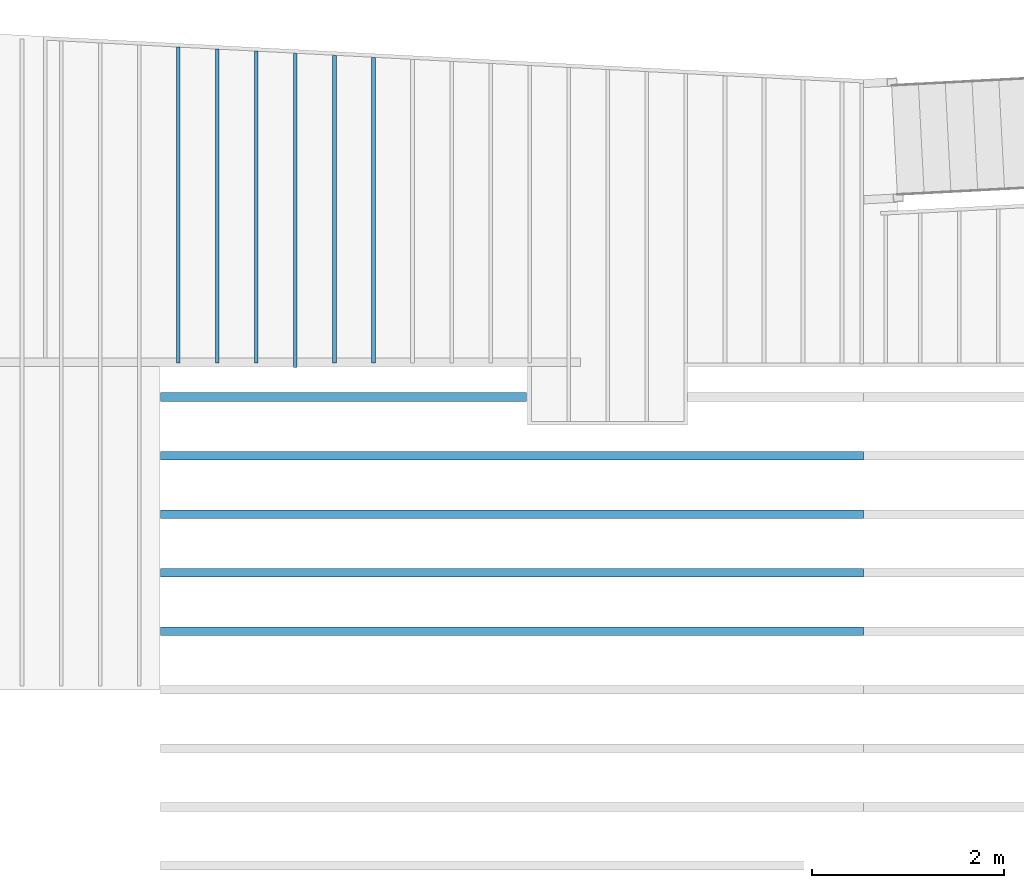
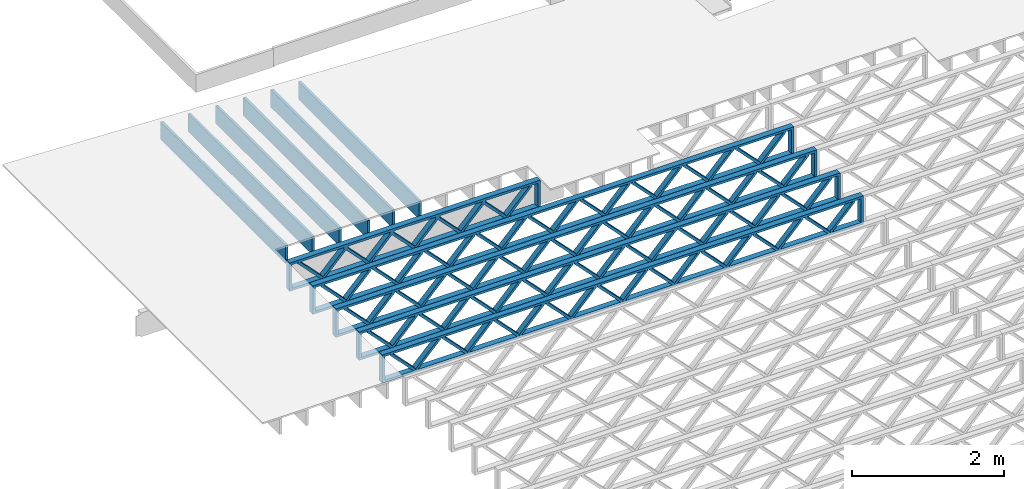
# One storey, part 3 of 23: 11 beams, 2 elements without a shape of their own.
"""IFC4 building model written with IfcOpenShell, lengths in feet."""

import ifcopenshell
import ifcopenshell.guid

model = None  # the IFC model being written
_history = None  # IfcOwnerHistory: only IFC2X3 demands one
_inside = {}  # id of a spatial element -> (the spatial element, [elements in it])
_under = {}  # id of a project, library or spatial element -> (it, [spatial elements below it])
_declared = {}  # id of a project -> (the project, [libraries it declares])
_typed = {}  # id of a type object -> (the type object, [elements of that type])
_made_of = {}  # id of a material, layer set ... -> (it, [elements and type objects made of it])


def new_model(schema):
    """Start an empty IFC model of exactly this schema.

    Asked for "IFC4X3", IfcOpenShell would pick the latest addendum, in which some entities
    have other attributes; the version numbers below select the first issue.
    IFC2X3 requires an IfcOwnerHistory on every rooted entity: one is made here for all.
    """
    global model, _history
    if schema == "IFC4X3":
        model = ifcopenshell.file(schema_version=(4, 3, 0, 0))
    else:
        model = ifcopenshell.file(schema=schema)
    _inside.clear()
    _under.clear()
    _declared.clear()
    _typed.clear()
    _made_of.clear()
    _history = None
    if model.schema == "IFC2X3":
        org = make("IfcOrganization", Name="unknown")
        user = make(
            "IfcPersonAndOrganization",
            ThePerson=make("IfcPerson", FamilyName="unknown"),
            TheOrganization=org,
        )
        app = make(
            "IfcApplication",
            ApplicationDeveloper=org,
            Version="unknown",
            ApplicationFullName="unknown",
            ApplicationIdentifier="unknown",
        )
        _history = make(
            "IfcOwnerHistory",
            OwningUser=user,
            OwningApplication=app,
            ChangeAction="ADDED",
            CreationDate=0,
        )
    return model


def make(cls, **values):
    """One entity of the class cls with the attributes given. An attribute that is None is left unset."""
    return model.create_entity(
        cls, **{name: value for name, value in values.items() if value is not None}
    )


def entity(cls, *values):
    """Any entity or typed value of the class cls, its attributes in the order of the schema. None: left unset."""
    e = model.create_entity(cls)
    for i, value in enumerate(values):
        if value is not None:
            e[i] = value
    return e


def rooted(cls, **values):
    """An entity with a GlobalId (a new one), such as an element, a storey or a relation."""
    return make(cls, GlobalId=ifcopenshell.guid.new(), OwnerHistory=_history, **values)


def si_unit(unit_type, name, prefix=None):
    """IfcSIUnit, for example si_unit("LENGTHUNIT", "METRE", prefix="MILLI")."""
    return make("IfcSIUnit", UnitType=unit_type, Prefix=prefix, Name=name)


def converted_unit(unit_type, name, factor, base, dimensions=None, offset=None):
    """IfcConversionBasedUnit, such as the inch: factor (a typed value) times the base unit."""
    return make(
        "IfcConversionBasedUnit"
        if offset is None
        else "IfcConversionBasedUnitWithOffset",
        ConversionOffset=offset,
        Dimensions=None
        if dimensions is None
        else entity("IfcDimensionalExponents", *dimensions),
        UnitType=unit_type,
        Name=name,
        ConversionFactor=make(
            "IfcMeasureWithUnit", ValueComponent=factor, UnitComponent=base
        ),
    )


def derived_unit(unit_type, elements):
    """IfcDerivedUnit: a product of units, each with its exponent."""
    return make(
        "IfcDerivedUnit",
        Elements=[
            make("IfcDerivedUnitElement", Unit=unit, Exponent=power)
            for unit, power in elements
        ],
        UnitType=unit_type,
    )


def assignment(units):
    """IfcUnitAssignment: the units of a project."""
    return None if units is None else make("IfcUnitAssignment", Units=units)


def point(xyz):
    """IfcCartesianPoint."""
    return None if xyz is None else make("IfcCartesianPoint", Coordinates=xyz)


def direction(xyz):
    """IfcDirection."""
    return None if xyz is None else make("IfcDirection", DirectionRatios=xyz)


def frame(location, z_axis=None, x_axis=None):
    """IfcAxis2Placement3D, a coordinate frame: its origin and axes. An axis left out is left unset."""
    return make(
        "IfcAxis2Placement3D",
        Location=point(location),
        Axis=direction(z_axis),
        RefDirection=direction(x_axis),
    )


def frame_2d(location, x_axis=None):
    """IfcAxis2Placement2D, a coordinate frame in the plane: its origin and x axis."""
    return make(
        "IfcAxis2Placement2D", Location=point(location), RefDirection=direction(x_axis)
    )


def origin():
    """The frame at (0, 0, 0) with its axes left unset."""
    return frame((0.0, 0.0, 0.0))


def origin_2d_with_axis():
    """The frame at (0, 0) in the plane with the x axis (1, 0) written out."""
    return frame_2d((0.0, 0.0), x_axis=(1.0, 0.0))


def place(relative_to, where):
    """IfcLocalPlacement: puts the frame where relative to a parent placement (None: the world)."""
    return make(
        "IfcLocalPlacement", PlacementRelTo=relative_to, RelativePlacement=where
    )


def context(
    kind, dimensions, precision=None, world=None, true_north=None, identifier=None
):
    """IfcGeometricRepresentationContext, for example the 3D "Model" context."""
    return make(
        "IfcGeometricRepresentationContext",
        ContextIdentifier=identifier,
        ContextType=kind,
        CoordinateSpaceDimension=dimensions,
        Precision=precision,
        WorldCoordinateSystem=world,
        TrueNorth=true_north,
    )


def subcontext(parent, identifier, kind, view, scale=None):
    """IfcGeometricRepresentationSubContext, for example "Body" below "Model"."""
    return make(
        "IfcGeometricRepresentationSubContext",
        ContextIdentifier=identifier,
        ContextType=kind,
        ParentContext=parent,
        TargetScale=scale,
        TargetView=view,
    )


def project(units=None, contexts=None):
    """IfcProject with its units and contexts."""
    return rooted(
        "IfcProject",
        Name="project",
        RepresentationContexts=contexts,
        UnitsInContext=assignment(units),
    )


def spatial(cls, under=None, at=None, **own):
    """A site, building, storey or space (cls), placed at a placement, below another one or the project."""
    s = rooted(cls, ObjectPlacement=at, **own)
    if under is not None:
        _under.setdefault(under.id(), (under, []))[1].append(s)
    return s


def profile(cls, at=None, kind="AREA", **sizes):
    """A parametric profile (cls). Its sizes go by their IFC names, for example OverallWidth=200.0."""
    return make(cls, ProfileType=kind, Position=at, **sizes)


def rectangle(**sizes):
    """IfcRectangleProfileDef."""
    return profile("IfcRectangleProfileDef", **sizes)


def extrude(swept, where, along, depth):
    """IfcExtrudedAreaSolid: the profile swept, set in the frame where, extruded along a direction by depth."""
    return make(
        "IfcExtrudedAreaSolid",
        SweptArea=swept,
        Position=where,
        ExtrudedDirection=direction(along),
        Depth=depth,
    )


def shape(context_of_items, identifier, shape_type, items):
    """IfcShapeRepresentation: the items that make up one representation, for example the "Body"."""
    return make(
        "IfcShapeRepresentation",
        ContextOfItems=context_of_items,
        RepresentationIdentifier=identifier,
        RepresentationType=shape_type,
        Items=items,
    )


def source(mapping_origin, context_of_items, identifier, shape_type, items):
    """IfcRepresentationMap: a shape defined once, which mapped items show again and again."""
    return make(
        "IfcRepresentationMap",
        MappingOrigin=mapping_origin,
        MappedRepresentation=shape(context_of_items, identifier, shape_type, items),
    )


def transform(
    local_origin,
    x_axis=None,
    y_axis=None,
    z_axis=None,
    scale=None,
    scale2=None,
    scale3=None,
    uniform=True,
):
    """IfcCartesianTransformationOperator3D, or its non-uniform kind. x_axis, y_axis, z_axis: its Axis1, 2, 3."""
    if uniform:
        return make(
            "IfcCartesianTransformationOperator3D",
            Axis1=direction(x_axis),
            Axis2=direction(y_axis),
            LocalOrigin=point(local_origin),
            Scale=scale,
            Axis3=direction(z_axis),
        )
    return make(
        "IfcCartesianTransformationOperator3DnonUniform",
        Axis1=direction(x_axis),
        Axis2=direction(y_axis),
        LocalOrigin=point(local_origin),
        Scale=scale,
        Axis3=direction(z_axis),
        Scale2=scale2,
        Scale3=scale3,
    )


def mapped(mapping_source, mapping_target):
    """IfcMappedItem: shows the shape of a source again, moved by a transform."""
    return make(
        "IfcMappedItem", MappingSource=mapping_source, MappingTarget=mapping_target
    )


def material(Name=None, Category=None):
    """IfcMaterial."""
    return make("IfcMaterial", Name=Name, Category=Category)


def material_profile(
    of_material, cross_section, Name=None, Category=None, Priority=None
):
    """IfcMaterialProfile: a cross section and its material."""
    return make(
        "IfcMaterialProfile",
        Name=Name,
        Material=of_material,
        Profile=cross_section,
        Priority=Priority,
        Category=Category,
    )


def profile_set(profiles, Name=None, composite=None):
    """IfcMaterialProfileSet."""
    return make(
        "IfcMaterialProfileSet",
        Name=Name,
        MaterialProfiles=profiles,
        CompositeProfile=composite,
    )


def profile_usage(for_profile_set, cardinal=None, extent=None):
    """IfcMaterialProfileSetUsage: how a profile set lies along its element."""
    return make(
        "IfcMaterialProfileSetUsage",
        ForProfileSet=for_profile_set,
        CardinalPoint=cardinal,
        ReferenceExtent=extent,
    )


def made_of(thing, what):
    """Note that an element or type object is made of a material, layer set ...; save() writes the relation."""
    if what is not None:
        _made_of.setdefault(what.id(), (what, []))[1].append(thing)
    return thing


def type_object(cls, material=None, **own):
    """A type object (cls), such as IfcWallType, which elements share."""
    return made_of(rooted(cls, **own), material)


def type_shapes(of_type, sources):
    """Give a type object the sources (RepresentationMaps) that its elements show as mapped items."""
    of_type.RepresentationMaps = sources


def element(
    cls,
    number,
    at=None,
    inside=None,
    cuts=None,
    type_object=None,
    material=None,
    context=None,
    identifier="Body",
    shape_type=None,
    held_by="IfcProductDefinitionShape",
    body=None,
    shapes=None,
    **own,
):
    """One element of the class cls, such as IfcWall. Its Tag is "e" and its number.

    at: its placement. inside: the storey or other place that contains it. cuts: it is an
    opening in that element (IfcRelVoidsElement). A single representation is given by context,
    identifier, shape_type and body (its items); several are given by shapes. held_by: the class
    of the entity that holds the representations. save() writes the other relations.
    """
    e = rooted(cls, Tag="e%d" % number, ObjectPlacement=at, **own)
    if body is not None:
        shapes = [shape(context, identifier, shape_type, body)]
    if shapes is not None:
        e.Representation = make(held_by, Representations=shapes)
    if inside is not None:
        _inside.setdefault(inside.id(), (inside, []))[1].append(e)
    if cuts is not None:
        rooted(
            "IfcRelVoidsElement", RelatingBuildingElement=cuts, RelatedOpeningElement=e
        )
    if type_object is not None:
        _typed.setdefault(type_object.id(), (type_object, []))[1].append(e)
    return made_of(e, material)


def aggregate(whole, parts):
    """IfcRelAggregates: a whole, such as a stair, and the parts it consists of."""
    return rooted("IfcRelAggregates", RelatingObject=whole, RelatedObjects=parts)


def save(model, path):
    """Write the relations noted so far, then the file.

    IfcRelAggregates (storeys below a building ...), IfcRelContainedInSpatialStructure (elements
    in a storey), IfcRelDefinesByType, IfcRelAssociatesMaterial and IfcRelDeclares: one each for
    every whole, place, type object, material and project.
    """
    for whole, parts in _under.values():
        aggregate(whole, parts)
    for where, things in _inside.values():
        rooted(
            "IfcRelContainedInSpatialStructure",
            RelatedElements=things,
            RelatingStructure=where,
        )
    for kind, things in _typed.values():
        rooted("IfcRelDefinesByType", RelatedObjects=things, RelatingType=kind)
    for what, things in _made_of.values():
        rooted("IfcRelAssociatesMaterial", RelatedObjects=things, RelatingMaterial=what)
    for by, libraries in _declared.values():
        rooted("IfcRelDeclares", RelatingContext=by, RelatedDefinitions=libraries)
    model.write(path)


model = new_model("IFC4")

# Units and contexts
model_context_1 = context("Model", 3, precision=0.0001, world=origin(), true_north=direction((6.12303176911189e-17, 1.0)))
model_context_2 = context("Model", 3, precision=0.0001, world=origin(), true_north=direction((6.12303176911189e-17, 1.0)))
body_context = subcontext(model_context_2, "Body", "Model", "MODEL_VIEW")
ifc_project = project(units=[converted_unit("LENGTHUNIT", "FOOT", entity("IfcRatioMeasure", 0.3048), si_unit("LENGTHUNIT", "METRE"), dimensions=[1, 0, 0, 0, 0, 0, 0]), converted_unit("AREAUNIT", "SQUARE FOOT", entity("IfcRatioMeasure", 0.09290304), si_unit("AREAUNIT", "SQUARE_METRE"), dimensions=[2, 0, 0, 0, 0, 0, 0]), converted_unit("VOLUMEUNIT", "CUBIC FOOT", entity("IfcRatioMeasure", 0.028316846592), si_unit("VOLUMEUNIT", "CUBIC_METRE"), dimensions=[3, 0, 0, 0, 0, 0, 0]), converted_unit("PLANEANGLEUNIT", "DEGREE", entity("IfcRatioMeasure", 0.0174532925199433), si_unit("PLANEANGLEUNIT", "RADIAN"), dimensions=[0, 0, 0, 0, 0, 0, 0]), si_unit("MASSUNIT", "GRAM", prefix="KILO"), derived_unit("MASSDENSITYUNIT", [(si_unit("MASSUNIT", "GRAM", prefix="KILO"), 1), (si_unit("LENGTHUNIT", "METRE"), -3)]), derived_unit("MOMENTOFINERTIAUNIT", [(si_unit("LENGTHUNIT", "METRE"), 4)]), si_unit("TIMEUNIT", "SECOND"), si_unit("FREQUENCYUNIT", "HERTZ"), si_unit("THERMODYNAMICTEMPERATUREUNIT", "DEGREE_CELSIUS"), derived_unit("THERMALTRANSMITTANCEUNIT", [(si_unit("MASSUNIT", "GRAM", prefix="KILO"), 1), (si_unit("THERMODYNAMICTEMPERATUREUNIT", "KELVIN"), -1), (si_unit("TIMEUNIT", "SECOND"), -3)]), derived_unit("VOLUMETRICFLOWRATEUNIT", [(si_unit("LENGTHUNIT", "METRE"), 3), (si_unit("TIMEUNIT", "SECOND"), -1)]), si_unit("ELECTRICCURRENTUNIT", "AMPERE"), si_unit("ELECTRICVOLTAGEUNIT", "VOLT"), si_unit("POWERUNIT", "WATT"), si_unit("FORCEUNIT", "NEWTON"), si_unit("ILLUMINANCEUNIT", "LUX"), si_unit("LUMINOUSFLUXUNIT", "LUMEN"), si_unit("LUMINOUSINTENSITYUNIT", "CANDELA"), derived_unit("USERDEFINED", [(si_unit("MASSUNIT", "GRAM", prefix="KILO"), -1), (si_unit("LENGTHUNIT", "METRE"), -2), (si_unit("TIMEUNIT", "SECOND"), 3), (si_unit("LUMINOUSFLUXUNIT", "LUMEN"), 1)]), derived_unit("LINEARVELOCITYUNIT", [(si_unit("LENGTHUNIT", "METRE"), 1), (si_unit("TIMEUNIT", "SECOND"), -1)]), si_unit("PRESSUREUNIT", "PASCAL"), derived_unit("USERDEFINED", [(si_unit("LENGTHUNIT", "METRE"), -2), (si_unit("MASSUNIT", "GRAM", prefix="KILO"), 1), (si_unit("TIMEUNIT", "SECOND"), -2)]), derived_unit("LINEARFORCEUNIT", [(si_unit("MASSUNIT", "GRAM", prefix="KILO"), 1), (si_unit("LENGTHUNIT", "METRE"), 1), (si_unit("TIMEUNIT", "SECOND"), -2), (si_unit("LENGTHUNIT", "METRE"), -1)]), derived_unit("PLANARFORCEUNIT", [(si_unit("MASSUNIT", "GRAM", prefix="KILO"), 1), (si_unit("LENGTHUNIT", "METRE"), 1), (si_unit("TIMEUNIT", "SECOND"), -2), (si_unit("LENGTHUNIT", "METRE"), -2)])], contexts=[model_context_1])

# Site, building, storey
site_placement = place(None, origin())
site = spatial("IfcSite", under=ifc_project, at=site_placement, CompositionType="ELEMENT")
building_placement = place(site_placement, origin())
building = spatial("IfcBuilding", under=site, at=building_placement, CompositionType="ELEMENT")
storey_placement = place(building_placement, frame((0.0, 0.0, 10.8020833333333)))
storey = spatial("IfcBuildingStorey", under=building, at=storey_placement, Name="2ND FLOOR", CompositionType="ELEMENT", Elevation=10.8020833333333)

# Assembly, beams
assembly_1_placement = place(storey_placement, origin())
assembly_1 = element("IfcElementAssembly", 1, at=assembly_1_placement, inside=storey, Name="Structural Beam System:Structural Framing System", ObjectType="Structural Beam System:Structural Framing System", AssemblyPlace="NOTDEFINED", PredefinedType="BEAM_GRID")
ifc_material_1 = material(Category="Materials")
ifc_material_profile_1 = material_profile(ifc_material_1, rectangle(XDim=0.9375, YDim=0.125000000000011, at=origin_2d_with_axis()))
ifc_profile_set_1 = profile_set([ifc_material_profile_1])
ifc_profile_usage_1 = profile_usage(ifc_profile_set_1, cardinal=8)
beam_type_1 = type_object("IfcBeamType", PredefinedType="BEAM", material=ifc_profile_set_1)
shared_shape_1 = source(origin(), body_context, "Body", "SweptSolid", [
    extrude(rectangle(XDim=0.9375, YDim=0.125000000000011, at=origin_2d_with_axis()), frame((-5.21569021559094, 0.0, 0.0), z_axis=(1.0, 0.0, 0.0), x_axis=(0.0, 0.0, -1.0)), (0.0, 0.0, 1.0), 10.4313804311819),
])
type_shapes(beam_type_1, [shared_shape_1])
beam_1_placement = place(assembly_1_placement, frame((-258.467327152129, 964.244294385257, -0.729166666666744), z_axis=(0.0, 0.0, 1.0), x_axis=(0.0, 1.0, 0.0)))
beam_1 = element("IfcBeam", 2, at=beam_1_placement, type_object=beam_type_1, material=ifc_profile_usage_1, PredefinedType="BEAM", context=body_context, shape_type="MappedRepresentation", body=[
    mapped(shared_shape_1, transform((0.0, 0.0, 0.0), scale=1.0)),
])
ifc_profile_usage_2 = profile_usage(ifc_profile_set_1, cardinal=8)
beam_type_2 = type_object("IfcBeamType", PredefinedType="BEAM", material=ifc_profile_set_1)
shared_shape_2 = source(origin(), body_context, "Body", "SweptSolid", [
    extrude(rectangle(XDim=0.9375, YDim=0.125000000000011, at=origin_2d_with_axis()), frame((-5.32050577415703, 0.0, 0.0), z_axis=(1.0, 0.0, 0.0), x_axis=(0.0, 0.0, -1.0)), (0.0, 0.0, 1.0), 10.6410115483141),
])
type_shapes(beam_type_2, [shared_shape_2])
beam_2_placement = place(assembly_1_placement, frame((-262.467327152129, 964.349109943823, -0.729166666666744), z_axis=(0.0, 0.0, 1.0), x_axis=(0.0, 1.0, 0.0)))
beam_2 = element("IfcBeam", 3, at=beam_2_placement, type_object=beam_type_2, material=ifc_profile_usage_2, PredefinedType="BEAM", context=body_context, shape_type="MappedRepresentation", body=[
    mapped(shared_shape_2, transform((0.0, 0.0, 0.0), scale=1.0)),
])
ifc_profile_usage_3 = profile_usage(ifc_profile_set_1, cardinal=8)
beam_type_3 = type_object("IfcBeamType", PredefinedType="BEAM", material=ifc_profile_set_1)
shared_shape_3 = source(origin(), body_context, "Body", "SweptSolid", [
    extrude(rectangle(XDim=0.9375, YDim=0.125000000000011, at=origin_2d_with_axis()), frame((-5.355444293679, 0.0, 0.0), z_axis=(1.0, 0.0, 0.0), x_axis=(0.0, 0.0, -1.0)), (0.0, 0.0, 1.0), 10.710888587358),
])
type_shapes(beam_type_3, [shared_shape_3])
beam_3_placement = place(assembly_1_placement, frame((-263.800660485462, 964.384048463345, -0.729166666666744), z_axis=(0.0, 0.0, 1.0), x_axis=(0.0, 1.0, 0.0)))
beam_3 = element("IfcBeam", 4, at=beam_3_placement, type_object=beam_type_3, material=ifc_profile_usage_3, PredefinedType="BEAM", context=body_context, shape_type="MappedRepresentation", body=[
    mapped(shared_shape_3, transform((0.0, 0.0, 0.0), scale=1.0)),
])

# Assembly, beam
assembly_2_placement = place(storey_placement, origin())
assembly_2 = element("IfcElementAssembly", 5, at=assembly_2_placement, inside=storey, Name="Structural Beam System:Structural Framing System", ObjectType="Structural Beam System:Structural Framing System", AssemblyPlace="NOTDEFINED", PredefinedType="BEAM_GRID")
ifc_material_2 = material(Name="WOOD TRUSS", Category="Materials")
ifc_material_profile_2 = material_profile(ifc_material_2, rectangle(XDim=1.73473973950632, YDim=0.125, at=frame_2d((-1.11022302462516e-16, 8.32667268468867e-17), x_axis=(1.0, 0.0))))
ifc_material_profile_3 = material_profile(ifc_material_2, rectangle(XDim=1.73473973950633, YDim=0.125, at=frame_2d((-1.11022302462516e-16, 8.32667268468867e-17), x_axis=(1.0, 0.0))))
ifc_material_profile_4 = material_profile(ifc_material_2, rectangle(XDim=1.73473973950632, YDim=0.125, at=frame_2d((-5.55111512312578e-17, 1.38777878078145e-16), x_axis=(1.0, 0.0))))
ifc_material_profile_5 = material_profile(ifc_material_2, rectangle(XDim=1.73473973950633, YDim=0.125, at=frame_2d((-1.11022302462516e-16, 8.32667268468867e-17), x_axis=(1.0, 0.0))))
ifc_material_profile_6 = material_profile(ifc_material_2, rectangle(XDim=1.73473973950632, YDim=0.125, at=frame_2d((-1.11022302462516e-16, 8.32667268468867e-17), x_axis=(1.0, 0.0))))
ifc_material_profile_7 = material_profile(ifc_material_2, rectangle(XDim=1.73473973950633, YDim=0.125, at=frame_2d((-2.77555756156289e-16, 3.05311331771918e-16), x_axis=(1.0, 0.0))))
ifc_material_profile_8 = material_profile(ifc_material_2, rectangle(XDim=1.73473973950632, YDim=0.124999999999999, at=frame_2d((-3.88578058618805e-16, -2.4980018054066e-16), x_axis=(1.0, 0.0))))
ifc_material_profile_9 = material_profile(ifc_material_2, rectangle(XDim=1.73473973950633, YDim=0.125, at=frame_2d((2.77555756156289e-16, -3.05311331771918e-16), x_axis=(1.0, 0.0))))
ifc_material_profile_10 = material_profile(ifc_material_2, rectangle(XDim=1.73473973950632, YDim=0.124999999999999, at=frame_2d((-1.11022302462516e-16, 8.32667268468867e-17), x_axis=(1.0, 0.0))))
ifc_material_profile_11 = material_profile(ifc_material_2, rectangle(XDim=1.73473973950633, YDim=0.125, at=origin_2d_with_axis()))
ifc_material_profile_12 = material_profile(ifc_material_2, rectangle(XDim=0.124999999999982, YDim=0.291666666666668, at=origin_2d_with_axis()))
ifc_material_profile_13 = material_profile(ifc_material_2, rectangle(XDim=0.124999999999932, YDim=0.291666666666664, at=origin_2d_with_axis()))
ifc_material_profile_14 = material_profile(ifc_material_2, rectangle(XDim=1.25000000000002, YDim=0.29166666666667, at=origin_2d_with_axis()))
ifc_material_profile_15 = material_profile(ifc_material_2, rectangle(XDim=1.25000000000004, YDim=0.291666666666667, at=origin_2d_with_axis()))
ifc_profile_set_2 = profile_set([ifc_material_profile_2, ifc_material_profile_3, ifc_material_profile_4, ifc_material_profile_5, ifc_material_profile_6, ifc_material_profile_7, ifc_material_profile_8, ifc_material_profile_9, ifc_material_profile_10, ifc_material_profile_11, ifc_material_profile_12, ifc_material_profile_13, ifc_material_profile_14, ifc_material_profile_15])
ifc_profile_usage_4 = profile_usage(ifc_profile_set_2, cardinal=8)
beam_type_4 = type_object("IfcBeamType", PredefinedType="BEAM", material=ifc_profile_set_2)
shared_shape_4 = source(origin(), body_context, "Body", "SweptSolid", [
    extrude(rectangle(XDim=1.73473973950632, YDim=0.125, at=frame_2d((-1.11022302462516e-16, 8.32667268468867e-17), x_axis=(1.0, 0.0))), frame((2.91681155651982, -0.145833333333334, 0.0), z_axis=(0.0, 1.0, 0.0), x_axis=(0.693383046997606, 0.0, 0.720569184836762)), (0.0, 0.0, 1.0), 0.291666666666667),
    extrude(rectangle(XDim=1.73473973950633, YDim=0.125, at=frame_2d((-1.11022302462516e-16, 8.32667268468867e-17), x_axis=(1.0, 0.0))), frame((1.66652568284655, -0.145833333333334, 0.0), z_axis=(0.0, 1.0, 0.0), x_axis=(0.69338304699761, 0.0, -0.720569184836758)), (0.0, 0.0, 1.0), 0.291666666666667),
    extrude(rectangle(XDim=1.73473973950632, YDim=0.125, at=frame_2d((-5.55111512312578e-17, 1.38777878078145e-16), x_axis=(1.0, 0.0))), frame((0.625142936836964, -0.145833333333334, 0.0), z_axis=(0.0, 1.0, 0.0), x_axis=(0.693383046997606, 0.0, 0.720569184836762)), (0.0, 0.0, 1.0), 0.291666666666667),
    extrude(rectangle(XDim=1.73473973950633, YDim=0.125, at=frame_2d((-1.11022302462516e-16, 8.32667268468867e-17), x_axis=(1.0, 0.0))), frame((-0.625142936836307, -0.145833333333334, 0.0), z_axis=(0.0, 1.0, 0.0), x_axis=(0.69338304699761, 0.0, -0.720569184836758)), (0.0, 0.0, 1.0), 0.291666666666667),
    extrude(rectangle(XDim=1.73473973950632, YDim=0.125, at=frame_2d((-1.11022302462516e-16, 8.32667268468867e-17), x_axis=(1.0, 0.0))), frame((-1.66652568284589, -0.145833333333334, 0.0), z_axis=(0.0, 1.0, 0.0), x_axis=(0.693383046997606, 0.0, 0.720569184836762)), (0.0, 0.0, 1.0), 0.291666666666667),
    extrude(rectangle(XDim=1.73473973950633, YDim=0.125, at=frame_2d((-2.77555756156289e-16, 3.05311331771918e-16), x_axis=(1.0, 0.0))), frame((-2.91681155651916, -0.145833333333334, 0.0), z_axis=(0.0, 1.0, 0.0), x_axis=(0.69338304699761, 0.0, -0.720569184836758)), (0.0, 0.0, 1.0), 0.291666666666667),
    extrude(rectangle(XDim=1.73473973950632, YDim=0.124999999999999, at=frame_2d((-3.88578058618805e-16, -2.4980018054066e-16), x_axis=(1.0, 0.0))), frame((5.20848017620267, -0.145833333333334, 0.0), z_axis=(0.0, 1.0, 0.0), x_axis=(0.693383046997607, 0.0, 0.720569184836761)), (0.0, 0.0, 1.0), 0.291666666666666),
    extrude(rectangle(XDim=1.73473973950633, YDim=0.125, at=frame_2d((2.77555756156289e-16, -3.05311331771918e-16), x_axis=(1.0, 0.0))), frame((3.9581943025294, -0.145833333333334, 0.0), z_axis=(0.0, 1.0, 0.0), x_axis=(0.69338304699761, 0.0, -0.720569184836758)), (0.0, 0.0, 1.0), 0.291666666666666),
    extrude(rectangle(XDim=1.73473973950632, YDim=0.124999999999999, at=frame_2d((-1.11022302462516e-16, 8.32667268468867e-17), x_axis=(1.0, 0.0))), frame((-3.95819430252874, -0.145833333333334, 0.0), z_axis=(0.0, 1.0, 0.0), x_axis=(0.693383046997606, 0.0, 0.720569184836762)), (0.0, 0.0, 1.0), 0.291666666666667),
    extrude(rectangle(XDim=1.73473973950633, YDim=0.125, at=origin_2d_with_axis()), frame((-5.20848017620202, -0.145833333333334, 0.0), z_axis=(0.0, 1.0, 0.0), x_axis=(0.69338304699761, 0.0, -0.720569184836758)), (0.0, 0.0, 1.0), 0.291666666666666),
    extrude(rectangle(XDim=0.124999999999982, YDim=0.291666666666668, at=origin_2d_with_axis()), frame((-6.25000390603229, 0.0, 0.687500000000054), z_axis=(1.0, 0.0, 0.0), x_axis=(0.0, 0.0, -1.0)), (0.0, 0.0, 1.0), 12.5000078120646),
    extrude(rectangle(XDim=0.124999999999932, YDim=0.291666666666664, at=origin_2d_with_axis()), frame((-6.25000390603208, 0.0, -0.687499999999984), z_axis=(1.0, 0.0, 0.0), x_axis=(0.0, 0.0, -1.0)), (0.0, 0.0, 1.0), 12.5000078120644),
    extrude(rectangle(XDim=1.25000000000002, YDim=0.29166666666667, at=origin_2d_with_axis()), frame((6.12500390603227, 0.0, 0.0), z_axis=(1.0, 0.0, 0.0), x_axis=(0.0, 0.0, -1.0)), (0.0, 0.0, 1.0), 0.12500000000002),
    extrude(rectangle(XDim=1.25000000000004, YDim=0.291666666666667, at=origin_2d_with_axis()), frame((-6.25000390603229, 0.0, 0.0), z_axis=(1.0, 0.0, 0.0), x_axis=(0.0, 0.0, -1.0)), (0.0, 0.0, 1.0), 0.125000000000023),
])
type_shapes(beam_type_4, [shared_shape_4])
beam_4_placement = place(assembly_2_placement, frame((-259.488164391561, 957.861934882651, -0.947916666657857)))
beam_4 = element("IfcBeam", 6, at=beam_4_placement, type_object=beam_type_4, material=ifc_profile_usage_4, PredefinedType="BEAM", context=body_context, shape_type="MappedRepresentation", body=[
    mapped(shared_shape_4, transform((0.0, 0.0, 0.0), scale=1.0)),
])

# Beam
ifc_profile_usage_5 = profile_usage(ifc_profile_set_1, cardinal=8)
beam_type_5 = type_object("IfcBeamType", PredefinedType="BEAM", material=ifc_profile_set_1)
shared_shape_5 = source(origin(), body_context, "Body", "SweptSolid", [
    extrude(rectangle(XDim=0.9375, YDim=0.125000000000011, at=origin_2d_with_axis()), frame((-5.25431782024765, 0.0, 0.0), z_axis=(1.0, 0.0, 0.0), x_axis=(0.0, 0.0, -1.0)), (0.0, 0.0, 1.0), 10.7378023029744),
])
type_shapes(beam_type_5, [shared_shape_5])
beam_5_placement = place(assembly_1_placement, frame((-261.133993818795, 964.116254196209, -0.729166666666744), z_axis=(0.0, 0.0, 1.0), x_axis=(0.0, 1.0, 0.0)))
beam_5 = element("IfcBeam", 7, at=beam_5_placement, type_object=beam_type_5, material=ifc_profile_usage_5, PredefinedType="BEAM", context=body_context, shape_type="MappedRepresentation", body=[
    mapped(shared_shape_5, transform((0.0, 0.0, 0.0), scale=1.0)),
])

ifc_profile_usage_6 = profile_usage(ifc_profile_set_1, cardinal=8)
beam_type_6 = type_object("IfcBeamType", PredefinedType="BEAM", material=ifc_profile_set_1)
shared_shape_6 = source(origin(), body_context, "Body", "SweptSolid", [
    extrude(rectangle(XDim=0.9375, YDim=0.125000000000011, at=origin_2d_with_axis()), frame((-5.39038281320103, 0.0, 0.0), z_axis=(1.0, 0.0, 0.0), x_axis=(0.0, 0.0, -1.0)), (0.0, 0.0, 1.0), 10.7807656264021),
])
type_shapes(beam_type_6, [shared_shape_6])
beam_6_placement = place(assembly_1_placement, frame((-265.133993818795, 964.418986982867, -0.729166666666744), z_axis=(0.0, 0.0, 1.0), x_axis=(0.0, 1.0, 0.0)))
beam_6 = element("IfcBeam", 8, at=beam_6_placement, type_object=beam_type_6, material=ifc_profile_usage_6, PredefinedType="BEAM", context=body_context, shape_type="MappedRepresentation", body=[
    mapped(shared_shape_6, transform((0.0, 0.0, 0.0), scale=1.0)),
])

ifc_profile_usage_7 = profile_usage(ifc_profile_set_1, cardinal=8)
beam_type_7 = type_object("IfcBeamType", PredefinedType="BEAM", material=ifc_profile_set_1)
shared_shape_7 = source(origin(), body_context, "Body", "SweptSolid", [
    extrude(rectangle(XDim=0.9375, YDim=0.125000000000011, at=origin_2d_with_axis()), frame((-5.25062873511297, 0.0, 0.0), z_axis=(1.0, 0.0, 0.0), x_axis=(0.0, 0.0, -1.0)), (0.0, 0.0, 1.0), 10.5012574702259),
])
type_shapes(beam_type_7, [shared_shape_7])
beam_7_placement = place(assembly_1_placement, frame((-259.800660485462, 964.279232904779, -0.729166666666744), z_axis=(0.0, 0.0, 1.0), x_axis=(0.0, 1.0, 0.0)))
beam_7 = element("IfcBeam", 9, at=beam_7_placement, type_object=beam_type_7, material=ifc_profile_usage_7, PredefinedType="BEAM", context=body_context, shape_type="MappedRepresentation", body=[
    mapped(shared_shape_7, transform((0.0, 0.0, 0.0), scale=1.0)),
])

aggregate(assembly_1, [beam_1, beam_2, beam_3, beam_5, beam_6, beam_7])

ifc_profile_usage_8 = profile_usage(ifc_profile_set_2, cardinal=8)
beam_type_8 = type_object("IfcBeamType", PredefinedType="BEAM", material=ifc_profile_set_2)
shared_shape_8 = source(origin(), body_context, "Body", "SweptSolid", [
    extrude(rectangle(XDim=1.73473973950632, YDim=0.124999999999999, at=frame_2d((5.55111512312578e-16, 7.21644966006352e-16), x_axis=(1.0, 0.0))), frame((8.37514585578398, -0.145833333333334, 0.0), z_axis=(0.0, 1.0, 0.0), x_axis=(0.693383046997606, 0.0, 0.720569184836762)), (0.0, 0.0, 1.0), 0.291666666666667),
    extrude(rectangle(XDim=1.73473973950633, YDim=0.125, at=origin_2d_with_axis()), frame((7.12485998211071, -0.145833333333334, 0.0), z_axis=(0.0, 1.0, 0.0), x_axis=(0.69338304699761, 0.0, -0.720569184836758)), (0.0, 0.0, 1.0), 0.291666666666666),
    extrude(rectangle(XDim=1.73473973950632, YDim=0.124999999999999, at=frame_2d((-1.11022302462516e-16, 8.32667268468867e-17), x_axis=(1.0, 0.0))), frame((5.79181154946831, -0.145833333333334, 0.0), z_axis=(0.0, 1.0, 0.0), x_axis=(0.693383046997606, 0.0, 0.720569184836762)), (0.0, 0.0, 1.0), 0.291666666666667),
    extrude(rectangle(XDim=1.73473973950633, YDim=0.125, at=origin_2d_with_axis()), frame((4.54152567579504, -0.145833333333334, 0.0), z_axis=(0.0, 1.0, 0.0), x_axis=(0.69338304699761, 0.0, -0.720569184836758)), (0.0, 0.0, 1.0), 0.291666666666666),
    extrude(rectangle(XDim=1.73473973950632, YDim=0.125, at=frame_2d((2.22044604925031e-16, 3.88578058618805e-16), x_axis=(1.0, 0.0))), frame((3.20847724315264, -0.145833333333334, 0.0), z_axis=(0.0, 1.0, 0.0), x_axis=(0.693383046997606, 0.0, 0.720569184836762)), (0.0, 0.0, 1.0), 0.291666666666667),
    extrude(rectangle(XDim=1.73473973950633, YDim=0.125, at=frame_2d((-1.11022302462516e-16, 8.32667268468867e-17), x_axis=(1.0, 0.0))), frame((1.95819136947937, -0.145833333333334, 0.0), z_axis=(0.0, 1.0, 0.0), x_axis=(0.69338304699761, 0.0, -0.720569184836758)), (0.0, 0.0, 1.0), 0.291666666666667),
    extrude(rectangle(XDim=1.73473973950632, YDim=0.125, at=frame_2d((-5.55111512312578e-17, 1.38777878078145e-16), x_axis=(1.0, 0.0))), frame((0.625142936836964, -0.145833333333334, 0.0), z_axis=(0.0, 1.0, 0.0), x_axis=(0.693383046997606, 0.0, 0.720569184836762)), (0.0, 0.0, 1.0), 0.291666666666667),
    extrude(rectangle(XDim=1.73473973950633, YDim=0.125, at=frame_2d((-1.11022302462516e-16, 8.32667268468867e-17), x_axis=(1.0, 0.0))), frame((-0.625142936836306, -0.145833333333334, 0.0), z_axis=(0.0, 1.0, 0.0), x_axis=(0.69338304699761, 0.0, -0.720569184836758)), (0.0, 0.0, 1.0), 0.291666666666667),
    extrude(rectangle(XDim=1.73473973950632, YDim=0.125, at=frame_2d((-1.11022302462516e-16, 8.32667268468867e-17), x_axis=(1.0, 0.0))), frame((-1.95819136947871, -0.145833333333334, 0.0), z_axis=(0.0, 1.0, 0.0), x_axis=(0.693383046997606, 0.0, 0.720569184836762)), (0.0, 0.0, 1.0), 0.291666666666667),
    extrude(rectangle(XDim=1.73473973950633, YDim=0.125, at=origin_2d_with_axis()), frame((-3.20847724315198, -0.145833333333334, 0.0), z_axis=(0.0, 1.0, 0.0), x_axis=(0.69338304699761, 0.0, -0.720569184836758)), (0.0, 0.0, 1.0), 0.291666666666667),
    extrude(rectangle(XDim=1.73473973950632, YDim=0.124999999999999, at=frame_2d((-1.11022302462516e-16, 8.32667268468867e-17), x_axis=(1.0, 0.0))), frame((-4.54152567579438, -0.145833333333334, 0.0), z_axis=(0.0, 1.0, 0.0), x_axis=(0.693383046997606, 0.0, 0.720569184836762)), (0.0, 0.0, 1.0), 0.291666666666667),
    extrude(rectangle(XDim=1.73473973950633, YDim=0.125, at=origin_2d_with_axis()), frame((-5.79181154946765, -0.145833333333334, 0.0), z_axis=(0.0, 1.0, 0.0), x_axis=(0.69338304699761, 0.0, -0.720569184836758)), (0.0, 0.0, 1.0), 0.291666666666666),
    extrude(rectangle(XDim=1.73473973950632, YDim=0.124999999999999, at=frame_2d((-1.11022302462516e-16, 8.32667268468867e-17), x_axis=(1.0, 0.0))), frame((-7.12485998211005, -0.145833333333334, 0.0), z_axis=(0.0, 1.0, 0.0), x_axis=(0.693383046997606, 0.0, 0.720569184836762)), (0.0, 0.0, 1.0), 0.291666666666667),
    extrude(rectangle(XDim=1.73473973950633, YDim=0.125, at=frame_2d((-2.77555756156289e-16, 3.05311331771918e-16), x_axis=(1.0, 0.0))), frame((-8.37514585578332, -0.145833333333334, 0.0), z_axis=(0.0, 1.0, 0.0), x_axis=(0.69338304699761, 0.0, -0.720569184836758)), (0.0, 0.0, 1.0), 0.291666666666666),
    extrude(rectangle(XDim=1.73473973950632, YDim=0.125, at=frame_2d((-7.21644966006352e-16, -5.55111512312578e-16), x_axis=(1.0, 0.0))), frame((10.9584801620997, -0.145833333333334, 0.0), z_axis=(0.0, 1.0, 0.0), x_axis=(0.693383046997606, 0.0, 0.720569184836762)), (0.0, 0.0, 1.0), 0.291666666666667),
    extrude(rectangle(XDim=1.73473973950633, YDim=0.125, at=origin_2d_with_axis()), frame((9.70819428842638, -0.145833333333334, 0.0), z_axis=(0.0, 1.0, 0.0), x_axis=(0.69338304699761, 0.0, -0.720569184836758)), (0.0, 0.0, 1.0), 0.291666666666666),
    extrude(rectangle(XDim=1.73473973950632, YDim=0.125, at=frame_2d((-5.55111512312578e-17, 8.32667268468867e-17), x_axis=(1.0, 0.0))), frame((-9.70819428842572, -0.145833333333334, 0.0), z_axis=(0.0, 1.0, 0.0), x_axis=(0.693383046997606, 0.0, 0.720569184836762)), (0.0, 0.0, 1.0), 0.291666666666667),
    extrude(rectangle(XDim=1.73473973950633, YDim=0.125, at=origin_2d_with_axis()), frame((-10.958480162099, -0.145833333333334, 0.0), z_axis=(0.0, 1.0, 0.0), x_axis=(0.69338304699761, 0.0, -0.720569184836758)), (0.0, 0.0, 1.0), 0.291666666666666),
    extrude(rectangle(XDim=0.124999999999982, YDim=0.291666666666668, at=origin_2d_with_axis()), frame((-12.0000038919293, 0.0, 0.687500000000054), z_axis=(1.0, 0.0, 0.0), x_axis=(0.0, 0.0, -1.0)), (0.0, 0.0, 1.0), 24.0000077838585),
    extrude(rectangle(XDim=0.124999999999932, YDim=0.291666666666664, at=origin_2d_with_axis()), frame((-12.0000038919291, 0.0, -0.687499999999984), z_axis=(1.0, 0.0, 0.0), x_axis=(0.0, 0.0, -1.0)), (0.0, 0.0, 1.0), 24.0000077838583),
    extrude(rectangle(XDim=1.25000000000002, YDim=0.29166666666667, at=origin_2d_with_axis()), frame((11.8750038919292, 0.0, 0.0), z_axis=(1.0, 0.0, 0.0), x_axis=(0.0, 0.0, -1.0)), (0.0, 0.0, 1.0), 0.12500000000002),
    extrude(rectangle(XDim=1.25000000000004, YDim=0.291666666666667, at=origin_2d_with_axis()), frame((-12.0000038919293, 0.0, 0.0), z_axis=(1.0, 0.0, 0.0), x_axis=(0.0, 0.0, -1.0)), (0.0, 0.0, 1.0), 0.125000000000023),
])
type_shapes(beam_type_8, [shared_shape_8])
beam_8_placement = place(assembly_2_placement, frame((-253.738164405664, 949.861934882651, -0.947916666657859)))
beam_8 = element("IfcBeam", 10, at=beam_8_placement, type_object=beam_type_8, material=ifc_profile_usage_8, PredefinedType="BEAM", context=body_context, shape_type="MappedRepresentation", body=[
    mapped(shared_shape_8, transform((0.0, 0.0, 0.0), scale=1.0)),
])

ifc_profile_usage_9 = profile_usage(ifc_profile_set_2, cardinal=8)
beam_9_placement = place(assembly_2_placement, frame((-253.738164405664, 953.861934882651, -0.947916666657859)))
beam_9 = element("IfcBeam", 11, at=beam_9_placement, type_object=beam_type_8, material=ifc_profile_usage_9, PredefinedType="BEAM", context=body_context, shape_type="MappedRepresentation", body=[
    mapped(shared_shape_8, transform((0.0, 0.0, 0.0), scale=1.0)),
])

ifc_profile_usage_10 = profile_usage(ifc_profile_set_2, cardinal=8)
beam_10_placement = place(assembly_2_placement, frame((-253.738164405664, 951.861934882651, -0.947916666657859)))
beam_10 = element("IfcBeam", 12, at=beam_10_placement, type_object=beam_type_8, material=ifc_profile_usage_10, PredefinedType="BEAM", context=body_context, shape_type="MappedRepresentation", body=[
    mapped(shared_shape_8, transform((0.0, 0.0, 0.0), scale=1.0)),
])

ifc_profile_usage_11 = profile_usage(ifc_profile_set_2, cardinal=8)
beam_type_9 = type_object("IfcBeamType", PredefinedType="BEAM", material=ifc_profile_set_2)
shared_shape_9 = source(origin(), body_context, "Body", "SweptSolid", [
    extrude(rectangle(XDim=1.73473973950632, YDim=0.124999999999999, at=frame_2d((5.55111512312578e-16, 7.21644966006352e-16), x_axis=(1.0, 0.0))), frame((8.37514585578398, -0.145833333333334, 0.0), z_axis=(0.0, 1.0, 0.0), x_axis=(0.693383046997606, 0.0, 0.720569184836762)), (0.0, 0.0, 1.0), 0.291666666666667),
    extrude(rectangle(XDim=1.73473973950633, YDim=0.125, at=origin_2d_with_axis()), frame((7.12485998211071, -0.145833333333334, 0.0), z_axis=(0.0, 1.0, 0.0), x_axis=(0.69338304699761, 0.0, -0.720569184836758)), (0.0, 0.0, 1.0), 0.291666666666666),
    extrude(rectangle(XDim=1.73473973950632, YDim=0.124999999999999, at=frame_2d((-1.11022302462516e-16, 8.32667268468867e-17), x_axis=(1.0, 0.0))), frame((5.79181154946831, -0.145833333333334, 0.0), z_axis=(0.0, 1.0, 0.0), x_axis=(0.693383046997606, 0.0, 0.720569184836762)), (0.0, 0.0, 1.0), 0.291666666666667),
    extrude(rectangle(XDim=1.73473973950633, YDim=0.125, at=origin_2d_with_axis()), frame((4.54152567579504, -0.145833333333334, 0.0), z_axis=(0.0, 1.0, 0.0), x_axis=(0.69338304699761, 0.0, -0.720569184836758)), (0.0, 0.0, 1.0), 0.291666666666666),
    extrude(rectangle(XDim=1.73473973950632, YDim=0.125, at=frame_2d((2.22044604925031e-16, 3.88578058618805e-16), x_axis=(1.0, 0.0))), frame((3.20847724315264, -0.145833333333334, 0.0), z_axis=(0.0, 1.0, 0.0), x_axis=(0.693383046997606, 0.0, 0.720569184836762)), (0.0, 0.0, 1.0), 0.291666666666667),
    extrude(rectangle(XDim=1.73473973950633, YDim=0.125, at=frame_2d((-1.11022302462516e-16, 8.32667268468867e-17), x_axis=(1.0, 0.0))), frame((1.95819136947937, -0.145833333333334, 0.0), z_axis=(0.0, 1.0, 0.0), x_axis=(0.69338304699761, 0.0, -0.720569184836758)), (0.0, 0.0, 1.0), 0.291666666666667),
    extrude(rectangle(XDim=1.73473973950632, YDim=0.125, at=frame_2d((-5.55111512312578e-17, 1.38777878078145e-16), x_axis=(1.0, 0.0))), frame((0.625142936836964, -0.145833333333334, 0.0), z_axis=(0.0, 1.0, 0.0), x_axis=(0.693383046997606, 0.0, 0.720569184836762)), (0.0, 0.0, 1.0), 0.291666666666667),
    extrude(rectangle(XDim=1.73473973950633, YDim=0.125, at=frame_2d((-1.11022302462516e-16, 8.32667268468867e-17), x_axis=(1.0, 0.0))), frame((-0.625142936836306, -0.145833333333334, 0.0), z_axis=(0.0, 1.0, 0.0), x_axis=(0.69338304699761, 0.0, -0.720569184836758)), (0.0, 0.0, 1.0), 0.291666666666667),
    extrude(rectangle(XDim=1.73473973950632, YDim=0.125, at=frame_2d((-1.11022302462516e-16, 8.32667268468867e-17), x_axis=(1.0, 0.0))), frame((-1.95819136947871, -0.145833333333334, 0.0), z_axis=(0.0, 1.0, 0.0), x_axis=(0.693383046997606, 0.0, 0.720569184836762)), (0.0, 0.0, 1.0), 0.291666666666667),
    extrude(rectangle(XDim=1.73473973950633, YDim=0.125, at=origin_2d_with_axis()), frame((-3.20847724315198, -0.145833333333334, 0.0), z_axis=(0.0, 1.0, 0.0), x_axis=(0.69338304699761, 0.0, -0.720569184836758)), (0.0, 0.0, 1.0), 0.291666666666667),
    extrude(rectangle(XDim=1.73473973950632, YDim=0.124999999999999, at=frame_2d((-1.11022302462516e-16, 8.32667268468867e-17), x_axis=(1.0, 0.0))), frame((-4.54152567579438, -0.145833333333334, 0.0), z_axis=(0.0, 1.0, 0.0), x_axis=(0.693383046997606, 0.0, 0.720569184836762)), (0.0, 0.0, 1.0), 0.291666666666667),
    extrude(rectangle(XDim=1.73473973950633, YDim=0.125, at=origin_2d_with_axis()), frame((-5.79181154946765, -0.145833333333334, 0.0), z_axis=(0.0, 1.0, 0.0), x_axis=(0.69338304699761, 0.0, -0.720569184836758)), (0.0, 0.0, 1.0), 0.291666666666666),
    extrude(rectangle(XDim=1.73473973950632, YDim=0.124999999999999, at=frame_2d((-1.11022302462516e-16, 8.32667268468867e-17), x_axis=(1.0, 0.0))), frame((-7.12485998211005, -0.145833333333334, 0.0), z_axis=(0.0, 1.0, 0.0), x_axis=(0.693383046997606, 0.0, 0.720569184836762)), (0.0, 0.0, 1.0), 0.291666666666667),
    extrude(rectangle(XDim=1.73473973950633, YDim=0.125, at=frame_2d((-2.77555756156289e-16, 3.05311331771918e-16), x_axis=(1.0, 0.0))), frame((-8.37514585578332, -0.145833333333334, 0.0), z_axis=(0.0, 1.0, 0.0), x_axis=(0.69338304699761, 0.0, -0.720569184836758)), (0.0, 0.0, 1.0), 0.291666666666666),
    extrude(rectangle(XDim=1.73473973950632, YDim=0.125, at=frame_2d((-7.21644966006352e-16, -5.55111512312578e-16), x_axis=(1.0, 0.0))), frame((10.9584801620997, -0.145833333333334, 0.0), z_axis=(0.0, 1.0, 0.0), x_axis=(0.693383046997606, 0.0, 0.720569184836762)), (0.0, 0.0, 1.0), 0.291666666666667),
    extrude(rectangle(XDim=1.73473973950633, YDim=0.125, at=origin_2d_with_axis()), frame((9.70819428842638, -0.145833333333334, 0.0), z_axis=(0.0, 1.0, 0.0), x_axis=(0.69338304699761, 0.0, -0.720569184836758)), (0.0, 0.0, 1.0), 0.291666666666666),
    extrude(rectangle(XDim=1.73473973950632, YDim=0.125, at=frame_2d((-5.55111512312578e-17, 8.32667268468867e-17), x_axis=(1.0, 0.0))), frame((-9.70819428842572, -0.145833333333334, 0.0), z_axis=(0.0, 1.0, 0.0), x_axis=(0.693383046997606, 0.0, 0.720569184836762)), (0.0, 0.0, 1.0), 0.291666666666667),
    extrude(rectangle(XDim=1.73473973950633, YDim=0.125, at=origin_2d_with_axis()), frame((-10.958480162099, -0.145833333333334, 0.0), z_axis=(0.0, 1.0, 0.0), x_axis=(0.69338304699761, 0.0, -0.720569184836758)), (0.0, 0.0, 1.0), 0.291666666666666),
    extrude(rectangle(XDim=0.124999999999982, YDim=0.291666666666668, at=origin_2d_with_axis()), frame((-12.0000038919293, 0.0, 0.687500000000054), z_axis=(1.0, 0.0, 0.0), x_axis=(0.0, 0.0, -1.0)), (0.0, 0.0, 1.0), 24.0000077838585),
    extrude(rectangle(XDim=0.124999999999932, YDim=0.291666666666664, at=origin_2d_with_axis()), frame((-12.0000038919291, 0.0, -0.687499999999984), z_axis=(1.0, 0.0, 0.0), x_axis=(0.0, 0.0, -1.0)), (0.0, 0.0, 1.0), 24.0000077838583),
    extrude(rectangle(XDim=1.25000000000002, YDim=0.29166666666667, at=origin_2d_with_axis()), frame((11.8750038919292, 0.0, 0.0), z_axis=(1.0, 0.0, 0.0), x_axis=(0.0, 0.0, -1.0)), (0.0, 0.0, 1.0), 0.12500000000002),
    extrude(rectangle(XDim=1.25000000000004, YDim=0.291666666666667, at=origin_2d_with_axis()), frame((-12.0000038919293, 0.0, 0.0), z_axis=(1.0, 0.0, 0.0), x_axis=(0.0, 0.0, -1.0)), (0.0, 0.0, 1.0), 0.125000000000023),
])
type_shapes(beam_type_9, [shared_shape_9])
beam_11_placement = place(assembly_2_placement, frame((-253.738164405664, 955.861934882651, -0.947916666657859)))
beam_11 = element("IfcBeam", 13, at=beam_11_placement, type_object=beam_type_9, material=ifc_profile_usage_11, PredefinedType="BEAM", context=body_context, shape_type="MappedRepresentation", body=[
    mapped(shared_shape_9, transform((0.0, 0.0, 0.0), scale=1.0)),
])

aggregate(assembly_2, [beam_4, beam_8, beam_9, beam_11, beam_10])

save(model, "model.ifc")
